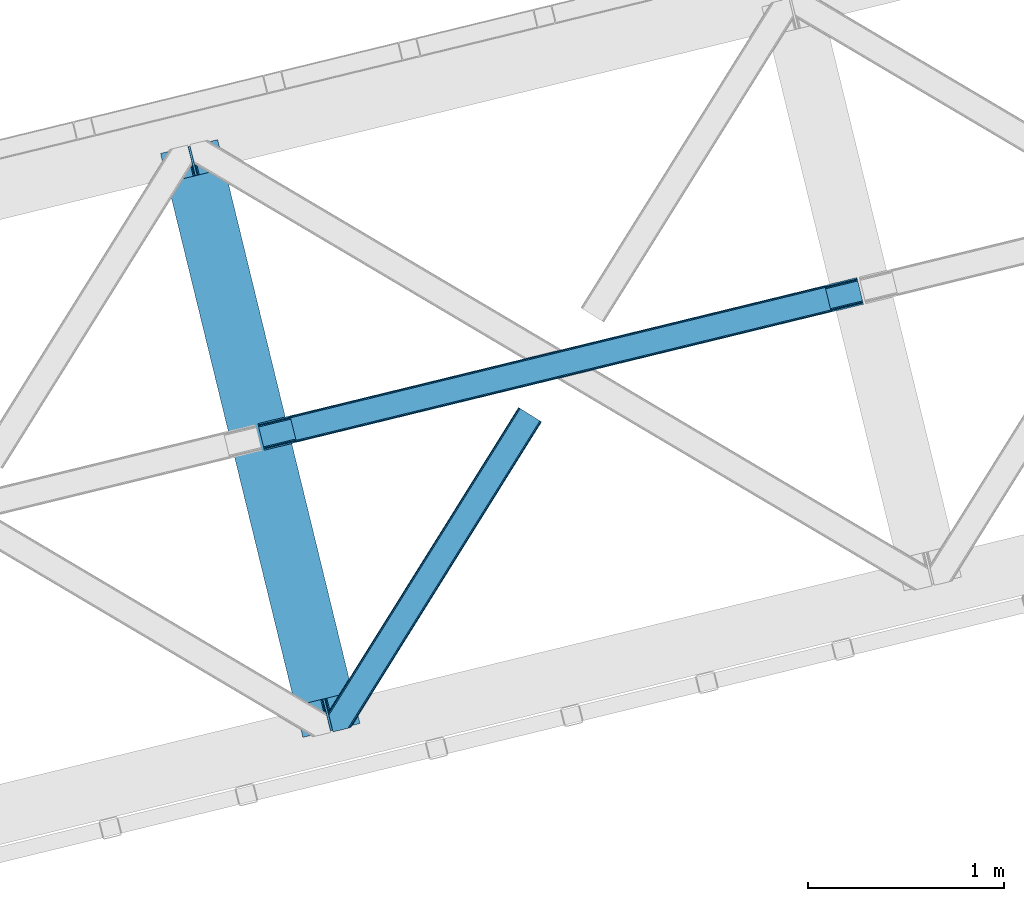
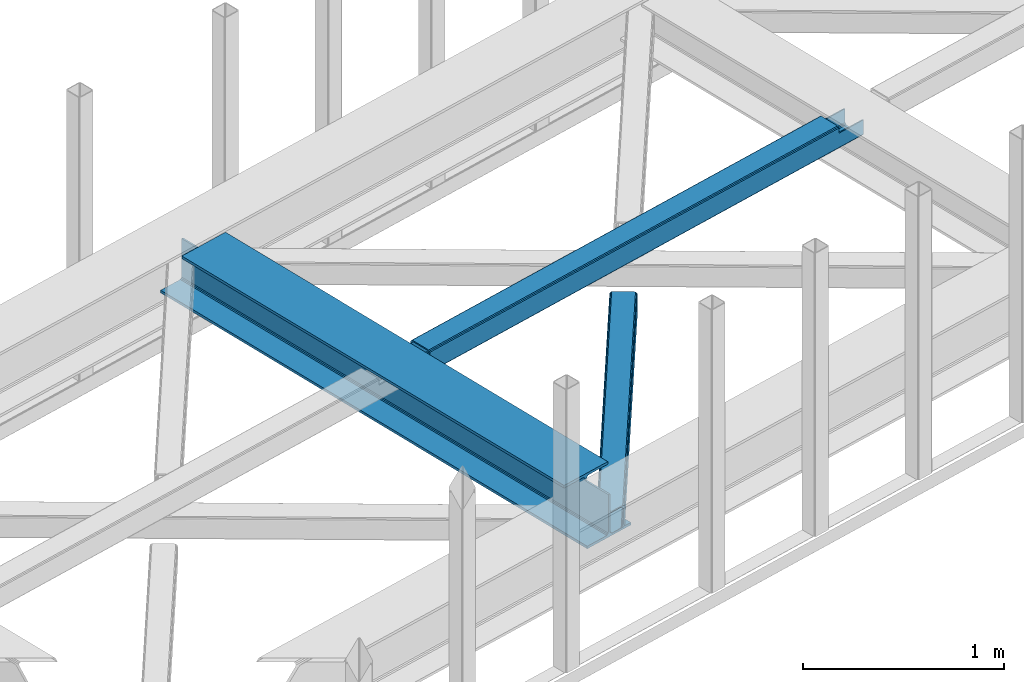
# One storey, part 46 of 66: 2 beams, 1 member.
"""IFC4 building model written with IfcOpenShell, lengths in millimetres."""

import ifcopenshell
import ifcopenshell.guid

model = None  # the IFC model being written
_history = None  # IfcOwnerHistory: only IFC2X3 demands one
_inside = {}  # id of a spatial element -> (the spatial element, [elements in it])
_under = {}  # id of a project, library or spatial element -> (it, [spatial elements below it])
_declared = {}  # id of a project -> (the project, [libraries it declares])
_typed = {}  # id of a type object -> (the type object, [elements of that type])
_made_of = {}  # id of a material, layer set ... -> (it, [elements and type objects made of it])


def new_model(schema):
    """Start an empty IFC model of exactly this schema.

    Asked for "IFC4X3", IfcOpenShell would pick the latest addendum, in which some entities
    have other attributes; the version numbers below select the first issue.
    IFC2X3 requires an IfcOwnerHistory on every rooted entity: one is made here for all.
    """
    global model, _history
    if schema == "IFC4X3":
        model = ifcopenshell.file(schema_version=(4, 3, 0, 0))
    else:
        model = ifcopenshell.file(schema=schema)
    _inside.clear()
    _under.clear()
    _declared.clear()
    _typed.clear()
    _made_of.clear()
    _history = None
    if model.schema == "IFC2X3":
        org = make("IfcOrganization", Name="unknown")
        user = make(
            "IfcPersonAndOrganization",
            ThePerson=make("IfcPerson", FamilyName="unknown"),
            TheOrganization=org,
        )
        app = make(
            "IfcApplication",
            ApplicationDeveloper=org,
            Version="unknown",
            ApplicationFullName="unknown",
            ApplicationIdentifier="unknown",
        )
        _history = make(
            "IfcOwnerHistory",
            OwningUser=user,
            OwningApplication=app,
            ChangeAction="ADDED",
            CreationDate=0,
        )
    return model


def make(cls, **values):
    """One entity of the class cls with the attributes given. An attribute that is None is left unset."""
    return model.create_entity(
        cls, **{name: value for name, value in values.items() if value is not None}
    )


def entity(cls, *values):
    """Any entity or typed value of the class cls, its attributes in the order of the schema. None: left unset."""
    e = model.create_entity(cls)
    for i, value in enumerate(values):
        if value is not None:
            e[i] = value
    return e


def rooted(cls, **values):
    """An entity with a GlobalId (a new one), such as an element, a storey or a relation."""
    return make(cls, GlobalId=ifcopenshell.guid.new(), OwnerHistory=_history, **values)


def si_unit(unit_type, name, prefix=None):
    """IfcSIUnit, for example si_unit("LENGTHUNIT", "METRE", prefix="MILLI")."""
    return make("IfcSIUnit", UnitType=unit_type, Prefix=prefix, Name=name)


def converted_unit(unit_type, name, factor, base, dimensions=None, offset=None):
    """IfcConversionBasedUnit, such as the inch: factor (a typed value) times the base unit."""
    return make(
        "IfcConversionBasedUnit"
        if offset is None
        else "IfcConversionBasedUnitWithOffset",
        ConversionOffset=offset,
        Dimensions=None
        if dimensions is None
        else entity("IfcDimensionalExponents", *dimensions),
        UnitType=unit_type,
        Name=name,
        ConversionFactor=make(
            "IfcMeasureWithUnit", ValueComponent=factor, UnitComponent=base
        ),
    )


def derived_unit(unit_type, elements):
    """IfcDerivedUnit: a product of units, each with its exponent."""
    return make(
        "IfcDerivedUnit",
        Elements=[
            make("IfcDerivedUnitElement", Unit=unit, Exponent=power)
            for unit, power in elements
        ],
        UnitType=unit_type,
    )


def assignment(units):
    """IfcUnitAssignment: the units of a project."""
    return None if units is None else make("IfcUnitAssignment", Units=units)


def point(xyz):
    """IfcCartesianPoint."""
    return None if xyz is None else make("IfcCartesianPoint", Coordinates=xyz)


def direction(xyz):
    """IfcDirection."""
    return None if xyz is None else make("IfcDirection", DirectionRatios=xyz)


def frame(location, z_axis=None, x_axis=None):
    """IfcAxis2Placement3D, a coordinate frame: its origin and axes. An axis left out is left unset."""
    return make(
        "IfcAxis2Placement3D",
        Location=point(location),
        Axis=direction(z_axis),
        RefDirection=direction(x_axis),
    )


def origin():
    """The frame at (0, 0, 0) with its axes left unset."""
    return frame((0.0, 0.0, 0.0))


def place(relative_to, where):
    """IfcLocalPlacement: puts the frame where relative to a parent placement (None: the world)."""
    return make(
        "IfcLocalPlacement", PlacementRelTo=relative_to, RelativePlacement=where
    )


def context(
    kind, dimensions, precision=None, world=None, true_north=None, identifier=None
):
    """IfcGeometricRepresentationContext, for example the 3D "Model" context."""
    return make(
        "IfcGeometricRepresentationContext",
        ContextIdentifier=identifier,
        ContextType=kind,
        CoordinateSpaceDimension=dimensions,
        Precision=precision,
        WorldCoordinateSystem=world,
        TrueNorth=true_north,
    )


def subcontext(parent, identifier, kind, view, scale=None):
    """IfcGeometricRepresentationSubContext, for example "Body" below "Model"."""
    return make(
        "IfcGeometricRepresentationSubContext",
        ContextIdentifier=identifier,
        ContextType=kind,
        ParentContext=parent,
        TargetScale=scale,
        TargetView=view,
    )


def project(units=None, contexts=None):
    """IfcProject with its units and contexts."""
    return rooted(
        "IfcProject",
        Name="project",
        RepresentationContexts=contexts,
        UnitsInContext=assignment(units),
    )


def spatial(cls, under=None, at=None, **own):
    """A site, building, storey or space (cls), placed at a placement, below another one or the project."""
    s = rooted(cls, ObjectPlacement=at, **own)
    if under is not None:
        _under.setdefault(under.id(), (under, []))[1].append(s)
    return s


def point_list(points):
    """IfcCartesianPointList2D or 3D."""
    cls = (
        "IfcCartesianPointList2D" if len(points[0]) == 2 else "IfcCartesianPointList3D"
    )
    return make(cls, CoordList=points)


def triangles(points, corners, closed=None, point_numbers=None):
    """IfcTriangulatedFaceSet: each triangle names its three corners, points numbered from 1."""
    return make(
        "IfcTriangulatedFaceSet",
        Coordinates=point_list(points),
        Closed=closed,
        CoordIndex=corners,
        PnIndex=point_numbers,
    )


def polygons(points, faces, closed=None, point_numbers=None):
    """IfcPolygonalFaceSet: a face is its outer loop, then its inner loops; points numbered from 1."""
    made = []
    for loops in faces:
        if len(loops) == 1:
            made.append(make("IfcIndexedPolygonalFace", CoordIndex=loops[0]))
        else:
            made.append(
                make(
                    "IfcIndexedPolygonalFaceWithVoids",
                    CoordIndex=loops[0],
                    InnerCoordIndices=loops[1:],
                )
            )
    return make(
        "IfcPolygonalFaceSet",
        Coordinates=point_list(points),
        Closed=closed,
        Faces=made,
        PnIndex=point_numbers,
    )


def shape(context_of_items, identifier, shape_type, items):
    """IfcShapeRepresentation: the items that make up one representation, for example the "Body"."""
    return make(
        "IfcShapeRepresentation",
        ContextOfItems=context_of_items,
        RepresentationIdentifier=identifier,
        RepresentationType=shape_type,
        Items=items,
    )


def material(Name=None, Category=None):
    """IfcMaterial."""
    return make("IfcMaterial", Name=Name, Category=Category)


def made_of(thing, what):
    """Note that an element or type object is made of a material, layer set ...; save() writes the relation."""
    if what is not None:
        _made_of.setdefault(what.id(), (what, []))[1].append(thing)
    return thing


def type_object(cls, material=None, **own):
    """A type object (cls), such as IfcWallType, which elements share."""
    return made_of(rooted(cls, **own), material)


def element(
    cls,
    number,
    at=None,
    inside=None,
    cuts=None,
    type_object=None,
    material=None,
    context=None,
    identifier="Body",
    shape_type=None,
    held_by="IfcProductDefinitionShape",
    body=None,
    shapes=None,
    **own,
):
    """One element of the class cls, such as IfcWall. Its Tag is "e" and its number.

    at: its placement. inside: the storey or other place that contains it. cuts: it is an
    opening in that element (IfcRelVoidsElement). A single representation is given by context,
    identifier, shape_type and body (its items); several are given by shapes. held_by: the class
    of the entity that holds the representations. save() writes the other relations.
    """
    e = rooted(cls, Tag="e%d" % number, ObjectPlacement=at, **own)
    if body is not None:
        shapes = [shape(context, identifier, shape_type, body)]
    if shapes is not None:
        e.Representation = make(held_by, Representations=shapes)
    if inside is not None:
        _inside.setdefault(inside.id(), (inside, []))[1].append(e)
    if cuts is not None:
        rooted(
            "IfcRelVoidsElement", RelatingBuildingElement=cuts, RelatedOpeningElement=e
        )
    if type_object is not None:
        _typed.setdefault(type_object.id(), (type_object, []))[1].append(e)
    return made_of(e, material)


def aggregate(whole, parts):
    """IfcRelAggregates: a whole, such as a stair, and the parts it consists of."""
    return rooted("IfcRelAggregates", RelatingObject=whole, RelatedObjects=parts)


def save(model, path):
    """Write the relations noted so far, then the file.

    IfcRelAggregates (storeys below a building ...), IfcRelContainedInSpatialStructure (elements
    in a storey), IfcRelDefinesByType, IfcRelAssociatesMaterial and IfcRelDeclares: one each for
    every whole, place, type object, material and project.
    """
    for whole, parts in _under.values():
        aggregate(whole, parts)
    for where, things in _inside.values():
        rooted(
            "IfcRelContainedInSpatialStructure",
            RelatedElements=things,
            RelatingStructure=where,
        )
    for kind, things in _typed.values():
        rooted("IfcRelDefinesByType", RelatedObjects=things, RelatingType=kind)
    for what, things in _made_of.values():
        rooted("IfcRelAssociatesMaterial", RelatedObjects=things, RelatingMaterial=what)
    for by, libraries in _declared.values():
        rooted("IfcRelDeclares", RelatingContext=by, RelatedDefinitions=libraries)
    model.write(path)


model = new_model("IFC4")

# Units and contexts
model_context = context("Model", 3, precision=0.01, world=origin(), true_north=direction((6.12303176911189e-17, 1.0)))
plan_context = context("Plan", 3, precision=0.01, world=origin(), true_north=direction((6.12303176911189e-17, 1.0)))
body_context = subcontext(model_context, "Body", "Model", "MODEL_VIEW")
ifc_project = project(units=[si_unit("LENGTHUNIT", "METRE", prefix="MILLI"), si_unit("AREAUNIT", "SQUARE_METRE"), si_unit("VOLUMEUNIT", "CUBIC_METRE"), converted_unit("PLANEANGLEUNIT", "DEGREE", entity("IfcRatioMeasure", 0.0174532925199433), si_unit("PLANEANGLEUNIT", "RADIAN"), dimensions=[0, 0, 0, 0, 0, 0, 0]), si_unit("MASSUNIT", "GRAM", prefix="KILO"), derived_unit("MASSDENSITYUNIT", [(si_unit("MASSUNIT", "GRAM", prefix="KILO"), 1), (si_unit("LENGTHUNIT", "METRE"), -3)]), derived_unit("MOMENTOFINERTIAUNIT", [(si_unit("LENGTHUNIT", "METRE"), 4)]), si_unit("TIMEUNIT", "SECOND"), si_unit("FREQUENCYUNIT", "HERTZ"), si_unit("THERMODYNAMICTEMPERATUREUNIT", "DEGREE_CELSIUS"), derived_unit("THERMALTRANSMITTANCEUNIT", [(si_unit("MASSUNIT", "GRAM", prefix="KILO"), 1), (si_unit("THERMODYNAMICTEMPERATUREUNIT", "KELVIN"), -1), (si_unit("TIMEUNIT", "SECOND"), -3)]), derived_unit("VOLUMETRICFLOWRATEUNIT", [(si_unit("LENGTHUNIT", "METRE"), 3), (si_unit("TIMEUNIT", "SECOND"), -1)]), derived_unit("MASSFLOWRATEUNIT", [(si_unit("MASSUNIT", "GRAM", prefix="KILO"), 1), (si_unit("TIMEUNIT", "SECOND"), -1)]), derived_unit("ROTATIONALFREQUENCYUNIT", [(si_unit("TIMEUNIT", "SECOND"), -1)]), si_unit("ELECTRICCURRENTUNIT", "AMPERE"), si_unit("ELECTRICVOLTAGEUNIT", "VOLT"), si_unit("POWERUNIT", "WATT"), si_unit("FORCEUNIT", "NEWTON", prefix="KILO"), si_unit("ILLUMINANCEUNIT", "LUX"), si_unit("LUMINOUSFLUXUNIT", "LUMEN"), si_unit("LUMINOUSINTENSITYUNIT", "CANDELA"), derived_unit("USERDEFINED", [(si_unit("MASSUNIT", "GRAM", prefix="KILO"), -1), (si_unit("LENGTHUNIT", "METRE"), -2), (si_unit("TIMEUNIT", "SECOND"), 3), (si_unit("LUMINOUSFLUXUNIT", "LUMEN"), 1)]), derived_unit("LINEARVELOCITYUNIT", [(si_unit("LENGTHUNIT", "METRE"), 1), (si_unit("TIMEUNIT", "SECOND"), -1)]), si_unit("PRESSUREUNIT", "PASCAL"), derived_unit("USERDEFINED", [(si_unit("LENGTHUNIT", "METRE"), -2), (si_unit("MASSUNIT", "GRAM", prefix="KILO"), 1), (si_unit("TIMEUNIT", "SECOND"), -2)]), derived_unit("LINEARFORCEUNIT", [(si_unit("MASSUNIT", "GRAM", prefix="KILO"), 1), (si_unit("LENGTHUNIT", "METRE"), 1), (si_unit("TIMEUNIT", "SECOND"), -2), (si_unit("LENGTHUNIT", "METRE"), -1)]), derived_unit("PLANARFORCEUNIT", [(si_unit("MASSUNIT", "GRAM", prefix="KILO"), 1), (si_unit("LENGTHUNIT", "METRE"), 1), (si_unit("TIMEUNIT", "SECOND"), -2), (si_unit("LENGTHUNIT", "METRE"), -2)])], contexts=[model_context, plan_context])

# Site, building, storey
site_placement = place(None, origin())
site = spatial("IfcSite", under=ifc_project, at=site_placement, CompositionType="ELEMENT")
building_placement = place(site_placement, origin())
building = spatial("IfcBuilding", under=site, at=building_placement, CompositionType="ELEMENT")
storey_placement = place(building_placement, frame((0.0, 0.0, 19800.0)))
storey = spatial("IfcBuildingStorey", under=building, at=storey_placement, Name="06", CompositionType="ELEMENT", Elevation=19800.0)

# Beams
ifc_material = material(Name="Metal painted (White)")
beam_type = type_object("IfcBeamType", PredefinedType="BEAM")
beam_1_placement = place(storey_placement, frame((-18024.61, 13401.24, 3807.02)))
element("IfcBeam", 1, at=beam_1_placement, inside=storey, type_object=beam_type, material=ifc_material, ObjectType="Steel Beam", PredefinedType="BEAM", context=body_context, shape_type="Tessellation", body=[
    polygons([(1018.1664837833, 71.0478278971021, 15.5000000000008), (1018.1664837833, 71.0478278971021, 0.0), (291.465617442448, 3052.25531830422, 0.0), (291.465617442448, 3052.25531830422, 15.5000000000008), (894.779372399336, 40.9709140873291, 15.5000000000008), (168.078506058485, 3022.17840449444, 15.5000000000008), (888.087028625368, 39.3395844888221, 16.8701684148028), (161.38616228452, 3020.54707489593, 16.8701684148028), (882.413533524757, 37.956610033654, 20.7720779386434), (155.712667183904, 3019.16410044077, 20.7720779386434), (878.622625296178, 37.0325360459162, 26.6116982174338), (151.921758955329, 3018.24002645303, 26.6116982174338), (877.291435352781, 36.7080444135007, 33.500000000001), (150.59056901193, 3017.91553482062, 33.500000000001), (140.875048430516, 3015.54727389071, 33.500000000001), (140.875048430516, 3015.54727389071, 259.000000000002), (150.59056901193, 3017.91553482062, 259.000000000002), (8.66293703438714e-12, 2981.20749040711, 0.0), (6.49720277579036e-12, 2981.20749040711, 15.4999999999965), (123.38711138397, 3011.28440421689, 15.5000000000008), (130.079455157935, 3012.91573381539, 16.8701684147984), (135.752950258553, 3014.29870827056, 20.7720779386434), (139.543858487119, 3015.22278225829, 26.6116982174294), (877.291435352781, 36.7080444135007, 259.000000000002), (867.575914771367, 34.3397834835992, 259.000000000002), (867.575914771369, 34.3397834835992, 33.500000000001), (866.24472482797, 34.0152918511837, 26.6116982174294), (862.453816599406, 33.0912178634546, 20.7720779386434), (856.780321498788, 31.7082434082822, 16.8701684147984), (850.087977724821, 30.0769138097752, 15.5000000000008), (726.700866340857, 0.0, 15.4999999999965), (726.700866340857, 0.0, 0.0), (838.124523615912, 197.385937999183, 259.069791973884), (186.469722099971, 2870.72539801219, 259.000000000002), (186.693115201822, 2869.80895360721, 259.617303331124), (186.705504045448, 2869.75812937344, 266.500003008253), (837.979344808145, 197.981416001708, 266.500002998871), (837.979694928899, 197.979979696973, 260.000004007589), (828.499586345876, 194.645865944434, 259.006343171919), (828.276216326111, 195.562317481914, 259.617303331124), (828.263827482484, 195.613141715689, 266.500003008253), (176.989986719784, 2867.38985508742, 266.500002998871), (176.989636599034, 2867.39129139215, 260.000004007589), (176.844830940692, 2867.98534020594, 259.07612046749), (176.754201518561, 2868.35713708228, 259.000000000002), (839.310832678068, 198.304685446393, 273.388305639783), (843.10110926677, 199.231350618306, 279.227924098781), (848.774180214294, 200.616065081981, 283.12983240061), (855.46637189544, 202.248018612798, 284.500000377228), (978.853400583278, 232.325271667905, 284.500000138971), (978.851730776626, 232.332121736639, 299.999995328161), (687.386308679356, 161.283492472598, 299.999995890962), (687.387978486005, 161.276642403863, 284.500000701776), (810.775007173849, 191.353895458974, 284.500000463519), (817.467494070001, 192.984637925557, 283.129832461069), (823.141405718761, 194.365903570083, 279.227924137322), (826.93294050574, 195.287407219375, 273.388305663684), (175.658498849859, 2867.06658564273, 273.388305639788), (171.868222261176, 2866.13992047082, 279.227924098781), (166.195151313642, 2864.75520600715, 283.129832400619), (159.502959632499, 2863.12325247633, 284.500000377228), (36.115930944662, 2833.04599942122, 284.500000138971), (36.1176007513137, 2833.03914935249, 299.999995328161), (327.583022848584, 2904.08777861653, 299.999995890962), (327.581353041935, 2904.09462868526, 284.500000701776), (204.19432435409, 2874.01737563015, 284.500000463519), (197.501837457939, 2872.38663316357, 283.12983246106), (191.827925809187, 2871.00536751904, 279.227924137322), (188.036391022187, 2870.08386386975, 273.388305663684)], [[[1, 2, 3, 4]], [[5, 1, 4, 6]], [[7, 5, 6, 8]], [[9, 7, 8, 10]], [[11, 9, 10, 12]], [[13, 11, 12, 14]], [[15, 16, 17, 14, 12, 10, 8, 6, 4, 3, 18, 19, 20, 21, 22, 23]], [[13, 24, 25, 26, 27, 28, 29, 30, 31, 32, 2, 1, 5, 7, 9, 11]], [[2, 32, 18, 3]], [[32, 31, 19, 18]], [[31, 30, 20, 19]], [[27, 26, 15, 23]], [[28, 27, 23, 22]], [[29, 28, 22, 21]], [[30, 29, 21, 20]], [[33, 24, 13, 14, 17, 34, 35, 36, 37, 38]], [[25, 39, 40, 41, 42, 43, 44, 16, 15, 26]], [[39, 25, 24, 33]], [[45, 34, 17, 16]], [[41, 40, 38, 37, 46, 47, 48, 49, 50, 51, 52, 53, 54, 55, 56, 57]], [[42, 58, 59, 60, 61, 62, 63, 64, 65, 66, 67, 68, 69, 36, 35, 43]], [[46, 37, 36, 69]], [[47, 46, 69, 68]], [[48, 47, 68, 67]], [[49, 48, 67, 66]], [[50, 49, 66, 65]], [[51, 50, 65, 64]], [[52, 51, 64, 63]], [[53, 52, 63, 62]], [[54, 53, 62, 61]], [[55, 54, 61, 60]], [[56, 55, 60, 59]], [[57, 56, 59, 58]], [[41, 57, 58, 42]]], closed=False),
])
beam_2_placement = place(storey_placement, frame((-17527.88, 14867.34, 3967.02)))
element("IfcBeam", 2, at=beam_2_placement, inside=storey, type_object=beam_type, material=ifc_material, ObjectType="Steel Beam", PredefinedType="BEAM", context=body_context, shape_type="Tessellation", body=[
    polygons([(31.1823923917571, 8.09507685195891, 17.8030399336114), (31.4978703677165, 6.80086440699001, 24.4999999999988), (3089.94374939708, 752.32940514057, 24.4999999999988), (3089.62827142111, 753.623617585539, 17.8030399336114), (30.2839871259056, 11.7806820741885, 12.1256313292298), (3088.72986615526, 757.309222807769, 12.1256313292298), (28.9394286278213, 17.2965800886753, 8.33210818105214), (3087.38530765717, 762.825120822256, 8.33210818105214), (27.353413740384, 23.8030254244661, 7.00000000000274), (3085.79929276974, 769.331566158046, 7.00000000000274), (4.21622439083043, 118.720708051131, 8.33210818105214), (5.8022392782634, 112.214262715343, 7.00000000000274), (3064.24811830762, 857.742803448923, 7.00000000000274), (3062.66210342018, 864.249248784712, 8.33210818105214), (2.87166589274607, 124.236606065618, 12.1256313292342), (3061.3175449221, 869.765146799198, 12.1256313292342), (1.9732606268946, 127.922211287848, 17.8030399336114), (3060.41913965625, 873.450752021428, 17.8030399336114), (1.65778265093302, 129.216423732814, 24.4999999999988), (3060.10366168029, 874.744964466399, 24.4999999999988), (33.1556530186517, -2.16573425859679e-12, 17.5000000000004), (33.1556530186517, -2.16573425859679e-12, 99.499999999999), (31.4978703677165, 6.80086440699001, 99.499999999999), (1.65778265093302, 129.216423732814, 99.499999999999), (2.16573425859679e-12, 136.017288139807, 99.499999999999), (2.16573425859679e-12, 136.017288139807, 17.5000000000004), (0.315477975961585, 134.723075694836, 10.803039933613), (1.21388324181306, 131.037470472612, 5.12563132923143), (2.55844173989742, 125.521572458121, 1.33210818105373), (4.14445662733471, 119.015127122331, 0.0), (29.011196391317, 17.0021610174739, 0.0), (30.5972112787521, 10.4957156816831, 1.33210818105373), (31.9417697768386, 4.97981766719418, 5.12563132923576), (32.8401750426901, 1.29421244496674, 10.803039933613), (3058.44587902937, 881.545828873391, 17.5000000000004), (3058.44587902937, 881.545828873391, 99.499999999999), (3060.1036616803, 874.744964466399, 99.499999999999), (3089.94374939708, 752.329405140575, 99.499999999999), (3091.60153204801, 745.528540733585, 99.499999999999), (3091.60153204801, 745.528540733585, 17.5000000000004), (3091.28605407205, 746.822753178554, 10.803039933613), (3090.3876488062, 750.508358400777, 5.12563132923576), (3089.04309030812, 756.024256415266, 1.33210818105373), (3087.45707542068, 762.530701751061, 0.0), (3062.5903356567, 864.543667855915, 0.0), (3061.00432076926, 871.050113191704, 1.33210818105373), (3059.65976227118, 876.566011206193, 5.12563132923143), (3058.76135700532, 880.251616428422, 10.803039933613), (2925.75994180942, 712.307865540883, 115.5000123926), (2925.81630989428, 712.321604759499, 100.117303289864), (2926.72300362931, 712.542621518195, 99.499999999999), (194.71860658079, 46.5876811586714, 99.5063429816656), (195.631369831906, 46.8101414944987, 100.117301735448), (195.690168193625, 46.8244741223546, 115.5), (2928.38078628024, 705.741757111203, 99.499999999999), (2927.47422618798, 705.520772937694, 100.117303484932), (2927.41464342032, 705.506249905351, 122.500007895425), (197.345360928041, 40.0229783796023, 122.500002534479), (197.338587096728, 40.0213271441435, 100.500009163303), (196.74820519572, 39.8773799905065, 99.5697919021647), (2896.88292546721, 834.958147714713, 99.5063429816656), (2895.97381660773, 834.736577551997, 100.117299778624), (2895.91744852288, 834.722838333381, 115.50000888136), (165.850080476841, 169.240033448181, 115.5), (165.840462203332, 169.237688832039, 100.50000941238), (165.250325295035, 169.093836777331, 99.5761204674868), (2894.85332685228, 841.668448882883, 99.5697919021647), (163.220745767762, 175.804071762182, 99.499999999999), (164.133244938506, 176.026503182397, 100.117301984524), (164.189439987621, 176.040201208966, 122.500002796667), (2894.25631754637, 841.522886341462, 122.500003994045), (2894.26642083519, 841.525349756029, 100.500018741102), (2894.56843170075, 840.227853719298, 129.196959150505), (2895.46176722634, 836.541012377604, 134.874360354937), (2896.8030582304, 831.024317672799, 138.667878733795), (2898.38810531641, 824.517636364724, 139.999985502214), (2923.25885436334, 722.505647815414, 139.999991354283), (2924.84634848092, 715.999563150009, 138.667885332354), (2926.19460804136, 710.484567539777, 134.874367586349), (2927.09837274857, 706.800269072827, 129.196966804773), (2925.44675217772, 713.602635936897, 122.196975799125), (2924.54298747051, 717.286934403856, 127.874376580702), (2923.19472791008, 722.801930014081, 131.667894326702), (2921.60723379249, 729.308014679486, 133.000000348631), (2900.05258461849, 817.718404755554, 132.999995276841), (2898.46753753248, 824.22508606363, 131.667888508414), (2897.12624652841, 829.741780768439, 127.874370129564), (2896.23291100282, 833.428622110128, 122.196968925133), (164.878528418698, 169.003207355192, 99.499999999999), (193.131726453727, 57.3201898040377, 131.667891818946), (191.545711566292, 63.8266351398307, 133.0), (194.476284951809, 51.8042917895488, 127.874368670764), (195.374690217663, 48.1186865673235, 122.196960066391), (169.994537104169, 152.237872430705, 133.0), (166.165558452801, 167.945821003215, 122.196960066391), (167.063963718652, 164.260215780989, 127.874368670764), (168.408522216734, 158.7443177665, 131.667891818946), (197.031411944058, 41.3175635421116, 129.196961104604), (196.136488323051, 45.0040174738959, 134.874366301861), (194.7942441573, 50.5204796458664, 138.667887185257), (193.209023953569, 57.0271186991972, 139.999994588639), (168.341882306926, 159.039986838386, 139.999994981919), (166.755021471176, 165.546225960032, 138.667887628704), (165.408105180718, 171.061549222925, 134.874366787843), (164.506189230952, 174.746298656824, 129.196961619)], [[[1, 2, 3, 4]], [[5, 1, 4, 6]], [[7, 5, 6, 8]], [[9, 7, 8, 10]], [[11, 12, 13, 14]], [[15, 11, 14, 16]], [[17, 15, 16, 18]], [[19, 17, 18, 20]], [[12, 9, 10, 13]], [[21, 22, 23, 2, 1, 5, 7, 9, 12, 11, 15, 17, 19, 24, 25, 26, 27, 28, 29, 30, 31, 32, 33, 34]], [[35, 36, 37, 20, 18, 16, 14, 13, 10, 8, 6, 4, 3, 38, 39, 40, 41, 42, 43, 44, 45, 46, 47, 48]], [[49, 50, 51, 38, 3, 2, 23, 52, 53, 54]], [[55, 39, 38, 51]], [[39, 55, 56, 57, 58, 59, 60, 22, 21, 40]], [[32, 31, 44, 43]], [[33, 32, 43, 42]], [[34, 33, 42, 41]], [[21, 34, 41, 40]], [[31, 30, 45, 44]], [[27, 26, 35, 48]], [[28, 27, 48, 47]], [[29, 28, 47, 46]], [[30, 29, 46, 45]], [[20, 37, 61, 62, 63, 64, 65, 66, 24, 19]], [[67, 36, 35, 26, 25, 68, 69, 70, 71, 72]], [[36, 67, 61, 37]], [[72, 71, 73, 74, 75, 76, 77, 78, 79, 80, 57, 56, 50, 49, 81, 82, 83, 84, 85, 86, 87, 88, 63, 62]], [[60, 52, 23, 22]], [[25, 24, 89, 68]], [[90, 91, 84, 83]], [[92, 90, 83, 82]], [[93, 92, 82, 81]], [[54, 93, 81, 49]], [[94, 85, 84, 91]], [[95, 64, 63, 88]], [[96, 95, 88, 87]], [[97, 96, 87, 86]], [[94, 97, 86, 85]], [[65, 64, 95, 96, 97, 94, 91, 90, 92, 93, 54, 53, 59, 58, 98, 99, 100, 101, 102, 103, 104, 105, 70, 69]], [[98, 58, 57, 80]], [[99, 98, 80, 79]], [[100, 99, 79, 78]], [[101, 100, 78, 77]], [[77, 76, 102, 101]], [[103, 102, 76, 75]], [[104, 103, 75, 74]], [[105, 104, 74, 73]], [[70, 105, 73, 71]]], closed=False),
])

# Member
member_type = type_object("IfcMemberType", PredefinedType="BRACE")
member_placement = place(storey_placement, frame((-17168.78, 13429.44, 3823.0)))
element("IfcMember", 3, at=member_placement, inside=storey, type_object=member_type, ObjectType="Steel Horizontal Brace", PredefinedType="BRACE", context=body_context, shape_type="Tessellation", body=[
    triangles([(986.15143432617, 1647.42967529297, 0.0), (1075.22041625976, 1591.82725524902, 0.0), (119.789199829102, 259.603921508788, 0.0), (154.548706054688, 117.003323364257, 0.0), (115.903390502928, 275.544808959959, 4.52065429687718), (117.571893310545, 268.698715209961, 1.33247680664135), (158.434515380857, 101.062435913085, 4.52065429687718), (156.76601257324, 107.908529663086, 1.33247680664135), (114.825549316403, 275.743634033202, 5.52059326172093), (115.126693725586, 275.922692871092, 5.35316162109302), (158.127557373045, 99.1206939697258, 5.27642211914281), (115.440628051758, 276.107565307617, 5.18107910156323), (158.231039428709, 99.7776306152336, 5.02062377929906), (158.183367919919, 99.4811370849602, 5.13457031250073), (115.540621948239, 276.16686401367, 5.12526855468968), (115.682473754881, 275.92036743164, 4.88574829101708), (158.334521484372, 100.433404541014, 4.76482543945531), (158.032214355466, 98.4928253173821, 5.52059326172093), (1085.71744995117, 1585.27416687012, 5.12526855468968), (1080.90030212402, 1588.27979736328, 1.33247680664135), (1088.93469543457, 1583.26498718262, 10.8039916992202), (114.209307861325, 21.8533172607422, 10.8039916992202), (109.46541137695, 20.6964111328125, 5.52059326172093), (1090.06485900879, 1582.55921630859, 17.5012573242202), (116.061520385741, 22.304452514647, 17.5012573242202), (6.75075073241896, 102.619317626952, 5.52059326172093), (31.3608764648416, 1.65803833007703, 5.52059326172093), (1090.06485900879, 1582.55921630859, 122.499499511719), (116.061520385741, 22.304452514647, 122.499499511719), (1088.93469543457, 1583.26498718262, 129.196765136719), (114.209307861325, 21.8533172607422, 129.196765136719), (1085.71744995117, 1585.27416687012, 134.87548828125), (108.931723022459, 20.566186523436, 134.87548828125), (1080.90030212402, 1588.27979736328, 138.668280029298), (101.038018798827, 18.6418853759751, 138.668280029298), (1075.22041625976, 1591.82725524902, 140.00075683594), (91.7292846679666, 16.3734191894528, 140.00075683594), (980.470385742186, 1650.97597045898, 1.33247680664135), (975.654400634765, 1653.98160095215, 5.12526855468968), (1.68826904296657, 100.410150146483, 10.9621215820334), (972.43599243164, 1655.99078063965, 10.8039916992202), (971.306991577147, 1656.69655151367, 17.5012573242202), (0.239520263668965, 99.7776306152336, 12.5201660156272), (0.0, 100.760128784179, 17.5012573242202), (5.79266967773219, 76.9941375732415, 140.00075683594), (986.15143432617, 1647.42967529297, 140.00075683594), (24.5612915039055, 0.0, 140.00075683594), (971.306991577147, 1656.69655151367, 122.499499511719), (0.0, 100.760128784179, 122.499499511719), (980.470385742186, 1650.97597045898, 138.668280029298), (3.57536315917969, 86.088931274413, 138.668280029298), (975.654400634765, 1653.98160095215, 134.87548828125), (1.69640808105396, 93.7989257812496, 134.87548828125), (972.43599243164, 1655.99078063965, 129.196765136719), (0.44067077636646, 98.950936889647, 129.196765136719), (29.9249176025369, 1.30689697265552, 6.99957275390625), (12.1969299316406, 74.0326904296871, 6.99957275390625), (8.99131164550636, 81.5473480224609, 8.3320495605476), (3.88697204589698, 84.812265014647, 12.5201660156272), (1069.28124389648, 1595.53284301758, 6.99957275390625), (81.9961578369112, 14.000308227538, 6.99957275390625), (992.090606689451, 1643.72292480469, 6.99957275390625), (981.588922119139, 1650.27485046387, 12.1248413085959), (978.370513916014, 1652.28286743164, 17.8035644531265), (2.75797119140407, 89.4445404052731, 17.8035644531265), (986.406069946288, 1647.26805725098, 8.3320495605476), (977.241513061523, 1652.98863830566, 24.5008300781265), (2.31730041503761, 91.2537322998032, 24.5008300781265), (977.241513061523, 1652.98863830566, 115.499926757813), (2.31730041503761, 91.2537322998032, 115.499926757813), (4.01370849609157, 84.2925292968739, 127.873590087893), (2.75797119140407, 89.4445404052731, 122.197192382813), (5.89266357421729, 76.5825347900391, 131.668707275392), (8.10997009277344, 67.4865783691403, 133.001184082033), (24.5612915039055, 0.0, 133.001184082033), (978.370513916014, 1652.28286743164, 122.197192382813), (981.588922119139, 1650.27485046387, 127.873590087893), (986.406069946288, 1647.26805725098, 131.668707275392), (992.090606689451, 1643.72292480469, 133.001184082033), (1069.28124389648, 1595.53284301758, 133.001184082033), (81.9961578369112, 14.000308227538, 133.001184082033), (1079.77711486816, 1588.97975463867, 12.1248413085959), (1082.99552307129, 1586.9717376709, 17.8035644531265), (1084.12568664551, 1586.26596679687, 24.5008300781265), (1074.96112976074, 1591.98654785156, 8.3320495605476), (1079.77711486816, 1588.97975463867, 127.873590087893), (1084.12568664551, 1586.26596679687, 115.499926757813), (1082.99552307129, 1586.9717376709, 122.197192382813), (1074.96112976074, 1591.98654785156, 131.668707275392), (91.3048919677713, 16.2699371337876, 131.668707275392), (99.1985961914033, 18.1942382812485, 127.873590087893), (104.476181030273, 19.4802062988274, 122.197192382813), (106.329556274413, 19.931341552734, 115.499926757813), (91.3048919677713, 16.2699371337876, 8.3320495605476), (104.476181030273, 19.4802062988274, 17.8035644531265), (99.1985961914033, 18.1942382812485, 12.1248413085959), (106.329556274413, 19.931341552734, 24.5008300781265)], [[1, 2, 3], [4, 3, 2], [5, 3, 4], [3, 5, 6], [4, 7, 5], [7, 4, 8], [9, 10, 11], [10, 12, 13], [13, 14, 10], [12, 15, 16], [16, 17, 12], [16, 5, 7], [7, 17, 16], [17, 13, 12], [14, 11, 10], [11, 18, 9], [19, 14, 13], [13, 20, 19], [13, 17, 20], [17, 7, 20], [7, 8, 20], [21, 22, 18], [18, 19, 21], [14, 19, 11], [18, 11, 19], [22, 23, 18], [21, 24, 25], [25, 22, 21], [2, 20, 4], [8, 4, 20], [23, 26, 18], [23, 27, 26], [9, 18, 26], [24, 28, 29], [29, 25, 24], [28, 30, 29], [31, 29, 30], [30, 32, 31], [33, 31, 32], [32, 34, 33], [35, 33, 34], [34, 36, 35], [37, 35, 36], [38, 6, 5], [5, 39, 38], [5, 15, 39], [40, 41, 9], [41, 39, 15], [42, 41, 40], [40, 43, 42], [43, 44, 42], [9, 26, 40], [38, 1, 6], [3, 6, 1], [36, 45, 37], [36, 46, 45], [45, 47, 37], [48, 42, 44], [44, 49, 48], [46, 50, 51], [51, 45, 46], [50, 52, 53], [53, 51, 50], [52, 54, 55], [55, 53, 52], [54, 48, 49], [49, 55, 54], [27, 56, 57], [26, 57, 58], [57, 26, 27], [59, 40, 26], [26, 58, 59], [43, 40, 59], [60, 57, 61], [60, 62, 57], [57, 56, 61], [63, 64, 65], [65, 59, 63], [66, 63, 59], [62, 66, 58], [58, 57, 62], [59, 58, 66], [64, 67, 68], [68, 65, 64], [67, 69, 70], [70, 68, 67], [71, 53, 72], [73, 74, 45], [74, 47, 45], [74, 75, 47], [51, 73, 45], [71, 51, 53], [71, 73, 51], [49, 68, 70], [55, 72, 53], [70, 72, 49], [72, 55, 49], [44, 68, 49], [43, 59, 65], [65, 68, 44], [44, 43, 65], [69, 76, 70], [72, 70, 76], [76, 77, 72], [71, 72, 77], [77, 78, 71], [73, 71, 78], [78, 79, 73], [74, 73, 79], [80, 74, 79], [74, 80, 81], [75, 74, 81], [21, 82, 83], [84, 28, 24], [21, 83, 24], [21, 19, 82], [83, 84, 24], [82, 19, 20], [60, 2, 1], [2, 85, 20], [85, 2, 60], [85, 82, 20], [30, 86, 32], [87, 28, 84], [28, 88, 30], [88, 28, 87], [30, 88, 86], [36, 80, 46], [34, 32, 86], [86, 89, 34], [89, 80, 36], [36, 34, 89], [63, 38, 39], [1, 62, 60], [1, 66, 62], [66, 1, 38], [63, 66, 38], [67, 42, 48], [41, 64, 63], [39, 41, 63], [64, 41, 42], [67, 64, 42], [50, 77, 52], [46, 80, 79], [79, 78, 46], [78, 77, 50], [50, 46, 78], [54, 52, 77], [48, 69, 67], [76, 48, 54], [48, 76, 69], [76, 54, 77], [35, 37, 90], [47, 81, 37], [81, 47, 75], [81, 90, 37], [91, 35, 90], [91, 33, 35], [33, 92, 31], [92, 33, 91], [29, 92, 93], [92, 29, 31], [61, 23, 94], [95, 96, 23], [96, 94, 23], [61, 27, 23], [27, 61, 56], [97, 95, 25], [22, 25, 95], [29, 97, 25], [97, 29, 93], [95, 23, 22], [80, 89, 90], [90, 81, 80], [89, 86, 91], [91, 90, 89], [86, 88, 92], [92, 91, 86], [88, 87, 93], [93, 92, 88], [87, 84, 93], [97, 93, 84], [84, 83, 97], [95, 97, 83], [83, 82, 95], [96, 95, 82], [82, 85, 96], [94, 96, 85], [85, 60, 94], [61, 94, 60]]),
])

save(model, "model.ifc")
